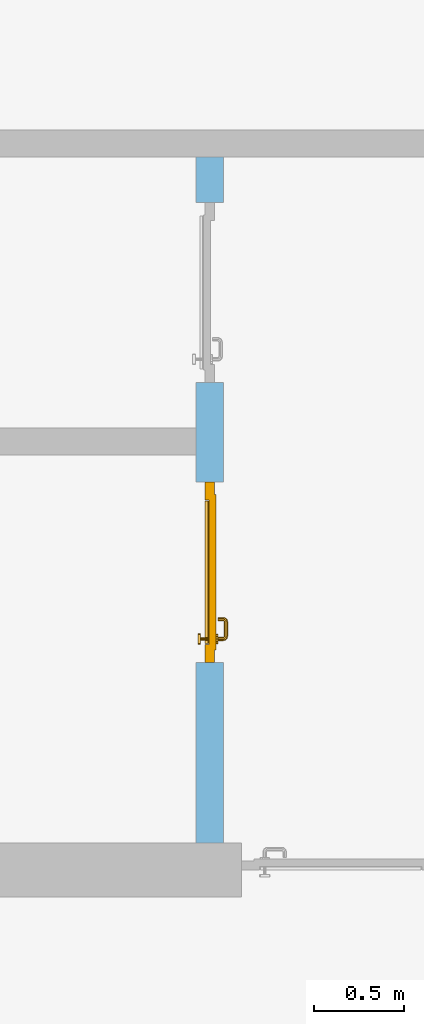
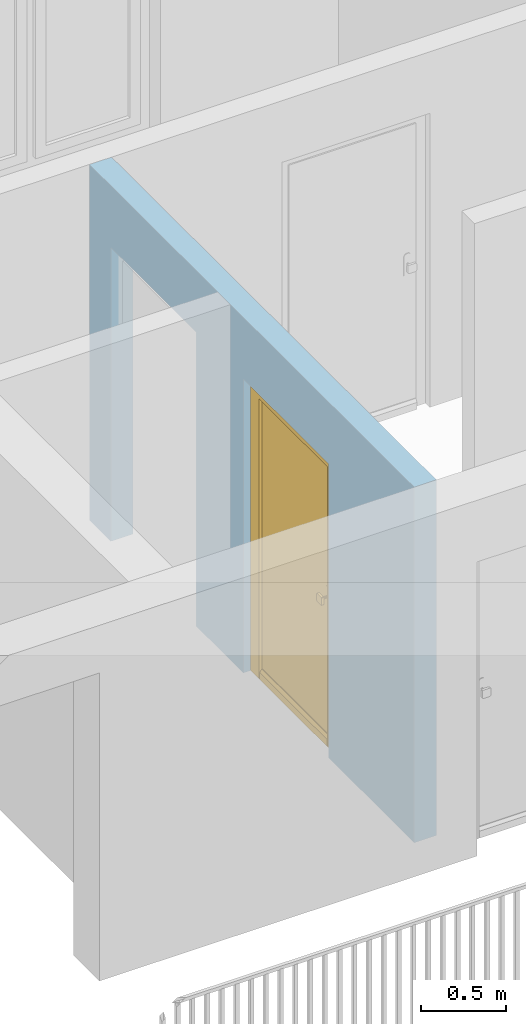
# One storey, part 19 of 54: 1 door, 2 openings, plus 1 element that does not belong to this part.
"""IFC4 building model written with IfcOpenShell, lengths in metres."""

from ifc_helpers import new_model, entity, si_unit, converted_unit, derived_unit, direction, frame, origin_with_axes, place, context, subcontext, project, spatial, polygons, source, transform, mapped, material, type_object, element, fill, save


model = new_model("IFC4")

# Units and contexts
model_context = context("Model", 3, precision=1e-05, world=origin_with_axes(), true_north=direction((0.0, 1.0)))
body_context = subcontext(model_context, "Body", "Model", "MODEL_VIEW")
ifc_project = project(units=[si_unit("LENGTHUNIT", "METRE"), si_unit("AREAUNIT", "SQUARE_METRE"), si_unit("VOLUMEUNIT", "CUBIC_METRE"), converted_unit("PLANEANGLEUNIT", "DEGREE", entity("IfcPlaneAngleMeasure", 0.0174532925199), si_unit("PLANEANGLEUNIT", "RADIAN"), dimensions=[0, 0, 0, 0, 0, 0, 0]), converted_unit("TIMEUNIT", "Year", entity("IfcTimeMeasure", 31556926.0), si_unit("TIMEUNIT", "SECOND"), dimensions=[0, 0, 1, 0, 0, 0, 0]), si_unit("MASSUNIT", "GRAM", prefix="KILO"), si_unit("THERMODYNAMICTEMPERATUREUNIT", "DEGREE_CELSIUS"), si_unit("LUMINOUSINTENSITYUNIT", "LUMEN"), si_unit("ENERGYUNIT", "JOULE", prefix="MEGA"), derived_unit("THERMALCONDUCTANCEUNIT", [(si_unit("POWERUNIT", "WATT"), 1), (si_unit("LENGTHUNIT", "METRE"), -1), (si_unit("THERMODYNAMICTEMPERATUREUNIT", "KELVIN"), -1)]), derived_unit("SPECIFICHEATCAPACITYUNIT", [(si_unit("ENERGYUNIT", "JOULE"), 1), (si_unit("MASSUNIT", "GRAM", prefix="KILO"), -1), (si_unit("THERMODYNAMICTEMPERATUREUNIT", "KELVIN"), -1)]), derived_unit("MASSDENSITYUNIT", [(si_unit("MASSUNIT", "GRAM", prefix="KILO"), 1), (si_unit("VOLUMEUNIT", "CUBIC_METRE"), -1)])], contexts=[model_context])

# Site, building, storey
site_placement = place(None, origin_with_axes())
site = spatial("IfcSite", under=ifc_project, at=site_placement, CompositionType="ELEMENT")
building_placement = place(site_placement, origin_with_axes())
building = spatial("IfcBuilding", under=site, at=building_placement, CompositionType="ELEMENT")
storey_placement = place(building_placement, frame((0.0, 0.0, 9.18), z_axis=(0.0, 0.0, 1.0), x_axis=(1.0, 0.0, 0.0)))
storey = spatial("IfcBuildingStorey", under=building, at=storey_placement, Name="3. Geschoss", CompositionType="ELEMENT", Elevation=9.18)

# Wall, openings, door
ifc_material = material()
wall_type = type_object("IfcWallType", Name="150", PredefinedType="NOTDEFINED")
wall_placement = place(storey_placement, frame((1.3378006196, 1.37118776896, 0.0), z_axis=(0.0, 0.0, 1.0), x_axis=(0.0, 1.0, 0.0)))
wall = element("IfcWall", 1, at=wall_placement, inside=storey, type_object=wall_type, material=ifc_material, Name="Wand-002", PredefinedType="NOTDEFINED", context=body_context, shape_type="Tessellation", body=[
    polygons([(1.3, 0.0, 0.0), (1.3, 0.0, 2.1), (2.3, 0.0, 2.1), (2.3, 0.0, 0.0), (2.85, 0.0, 0.0), (2.85, 0.0, 2.1), (3.85, 0.0, 2.1), (3.85, 0.0, 0.0), (4.1, 0.0, 0.0), (4.1, 0.0, 2.54), (0.3, 0.0, 2.54), (0.3, 0.0, 0.0), (1.3, 0.1, 0.0), (1.3, 0.15, 0.0), (1.3, 0.15, 2.1), (2.3, 0.15, 2.1), (2.3, 0.1, 0.0), (2.3, 0.15, 0.0), (2.85, 0.15, 0.0), (2.85, 0.15, 2.1), (3.85, 0.15, 2.1), (3.85, 0.15, 0.0), (4.1, 0.15, 0.0), (4.1, 0.15, 2.54), (0.3, 0.15, 2.54), (0.3, 0.15, 0.0)], [[[1, 2, 3, 4, 5, 6, 7, 8, 9, 10, 11, 12]], [[2, 1, 13, 14, 15]], [[3, 2, 15, 16]], [[17, 4, 3, 16, 18]], [[4, 17, 18, 19, 5]], [[19, 20, 6, 5]], [[20, 21, 7, 6]], [[21, 22, 8, 7]], [[23, 9, 8, 22]], [[23, 24, 10, 9]], [[25, 11, 10, 24]], [[12, 11, 25, 26]], [[13, 1, 12, 26, 14]], [[19, 18, 16, 15, 14, 26, 25, 24, 23, 22, 21, 20]]], closed=True),
])
opening_1_placement = place(wall_placement, frame((3.35, 0.0, 0.0), z_axis=(0.0, 0.0, 1.0), x_axis=(1.0, 0.0, 0.0)))
element("IfcOpeningElement", 2, at=opening_1_placement, cuts=wall, context=body_context, identifier="Reference", shape_type="Tessellation", body=[
    polygons([(-0.5, 0.1, 0.0), (-0.5, 0.1, 2.1), (-0.5, 0.151, 2.1), (-0.5, 0.151, 0.0), (-0.5, -0.001, 0.0), (-0.5, -0.001, 2.1), (0.5, 0.1, 2.1), (0.5, 0.151, 2.1), (0.5, -0.001, 2.1), (0.5, 0.151, 0.0), (0.5, 0.1, 0.0), (0.5, -0.001, 0.0)], [[[1, 2, 3, 4]], [[2, 1, 5, 6]], [[7, 8, 3, 2, 6, 9]], [[8, 10, 4, 3]], [[1, 4, 10, 11, 12, 5]], [[6, 5, 12, 9]], [[7, 11, 10, 8]], [[11, 7, 9, 12]]], closed=True),
])
opening_2_placement = place(wall_placement, frame((1.8, 0.0, 0.0), z_axis=(0.0, 0.0, 1.0), x_axis=(1.0, 0.0, 0.0)))
opening_2 = element("IfcOpeningElement", 3, at=opening_2_placement, cuts=wall, context=body_context, identifier="Reference", shape_type="Tessellation", body=[
    polygons([(-0.5, 0.1, 0.0), (-0.5, 0.1, 2.1), (-0.5, 0.151, 2.1), (-0.5, 0.151, 0.0), (-0.5, -0.001, 0.0), (-0.5, -0.001, 2.1), (0.5, 0.1, 2.1), (0.5, 0.151, 2.1), (0.5, -0.001, 2.1), (0.5, 0.151, 0.0), (0.5, 0.1, 0.0), (0.5, -0.001, 0.0)], [[[1, 2, 3, 4]], [[2, 1, 5, 6]], [[7, 8, 3, 2, 6, 9]], [[8, 10, 4, 3]], [[1, 4, 10, 11, 12, 5]], [[6, 5, 12, 9]], [[7, 11, 10, 8]], [[11, 7, 9, 12]]], closed=True),
])
door_type = type_object("IfcDoorType", Name="Eingang 01 1-Fl 26", OperationType="SINGLE_SWING_LEFT", PredefinedType="DOOR")
shared_shape = source(origin_with_axes(), body_context, "Body", "Tessellation", [
    polygons([(-0.5, -0.05, 0.0), (-0.5, -0.05, 2.1), (-0.5, -0.03, 2.1), (-0.5, -0.03, 0.0), (-0.4, -0.05, 0.0), (-0.4, -0.05, 2.0), (-0.1301, -0.05, 2.0), (-0.0001, -0.05, 2.0), (0.4, -0.05, 2.0), (0.4, -0.05, 0.0), (0.5, -0.05, 0.0), (0.5, -0.05, 2.1), (0.5, -0.03, 2.1), (0.5, -0.03, 0.0), (0.4, -0.03, 0.0), (0.4, -0.03, 2.0), (-0.0001, -0.03, 2.0), (-0.1301, -0.03, 2.0), (-0.4, -0.03, 2.0), (-0.4, -0.03, 0.0)], [[[1, 2, 3, 4]], [[1, 5, 6, 7, 8, 9, 10, 11, 12, 2]], [[2, 12, 13, 3]], [[4, 3, 13, 14, 15, 16, 17, 18, 19, 20]], [[5, 1, 4, 20]], [[6, 5, 20, 19]], [[7, 6, 19, 18]], [[8, 7, 18, 17]], [[9, 8, 17, 16]], [[10, 9, 16, 15]], [[11, 10, 15, 14]], [[12, 11, 14, 13]]], closed=True),
    polygons([(-0.5, -0.03, 0.0), (-0.5, -0.03, 2.1), (-0.5, 0.0, 2.1), (-0.5, 0.0, 0.0), (-0.43, -0.03, 0.0), (-0.43, -0.03, 2.03), (-0.1001, -0.03, 2.03), (-0.0301, -0.03, 2.03), (0.43, -0.03, 2.03), (0.43, -0.03, 0.0), (0.5, -0.03, 0.0), (0.5, -0.03, 2.1), (0.5, 0.0, 2.1), (0.5, 0.0, 0.0), (0.43, 0.0, 0.0), (0.43, 0.0, 2.03), (-0.0301, 0.0, 2.03), (-0.1001, 0.0, 2.03), (-0.43, 0.0, 2.03), (-0.43, 0.0, 0.0)], [[[1, 2, 3, 4]], [[1, 5, 6, 7, 8, 9, 10, 11, 12, 2]], [[2, 12, 13, 3]], [[4, 3, 13, 14, 15, 16, 17, 18, 19, 20]], [[5, 1, 4, 20]], [[6, 5, 20, 19]], [[7, 6, 19, 18]], [[8, 7, 18, 17]], [[9, 8, 17, 16]], [[10, 9, 16, 15]], [[11, 10, 15, 14]], [[12, 11, 14, 13]]], closed=True),
    polygons([(-0.43, 0.01, 0.0), (-0.43, 0.01, 2.03), (0.43, 0.01, 2.03), (0.43, 0.01, 0.0), (-0.43, -0.03, 0.0), (-0.43, -0.03, 2.03), (0.43, -0.03, 2.03), (0.43, -0.03, 0.0)], [[[1, 2, 3, 4]], [[1, 5, 6, 2]], [[2, 6, 7, 3]], [[3, 7, 8, 4]], [[4, 8, 5, 1]], [[8, 7, 6, 5]]], closed=True),
    polygons([(-0.395, -0.05, 0.0), (0.395, -0.05, 0.0), (0.395, -0.05, 0.05), (-0.395, -0.05, 0.05), (-0.395, -0.03, 0.0), (0.395, -0.03, 0.0), (0.395, -0.03, 0.07), (0.395, -0.035, 0.07), (-0.395, -0.035, 0.07), (-0.395, -0.03, 0.07)], [[[1, 2, 3, 4]], [[5, 6, 2, 1]], [[2, 6, 7, 8, 3]], [[4, 3, 8, 9]], [[1, 4, 9, 10, 5]], [[10, 7, 6, 5]], [[9, 8, 7, 10]]], closed=True),
    polygons([(0.3835, 0.02, 1.0733826859), (0.37, 0.02, 1.077), (0.37, 0.0199, 1.077), (0.3835, 0.0199, 1.0733826859), (0.393382685902, 0.02, 1.0635), (0.397, 0.02, 1.05), (0.393382685902, 0.02, 1.0365), (0.3835, 0.02, 1.0266173141), (0.37, 0.02, 1.023), (0.3565, 0.02, 1.0266173141), (0.346617314098, 0.02, 1.0365), (0.343, 0.02, 1.05), (0.346617314098, 0.02, 1.0635), (0.3565, 0.02, 1.0733826859), (0.3565, 0.0199, 1.0733826859), (0.37, 0.0101, 1.077), (0.3835, 0.0101, 1.0733826859), (0.393382685902, 0.0199, 1.0635), (0.397, 0.0199, 1.05), (0.393382685902, 0.0199, 1.0365), (0.3835, 0.0199, 1.0266173141), (0.37, 0.0199, 1.023), (0.3565, 0.0199, 1.0266173141), (0.346617314098, 0.0199, 1.0365), (0.343, 0.0199, 1.05), (0.346617314098, 0.0199, 1.0635), (0.3565, 0.0101, 1.0733826859), (0.37, 0.01, 1.077), (0.3835, 0.01, 1.0733826859), (0.393382685902, 0.0101, 1.0635), (0.397, 0.0101, 1.05), (0.393382685902, 0.0101, 1.0365), (0.3835, 0.0101, 1.0266173141), (0.37, 0.0101, 1.023), (0.3565, 0.0101, 1.0266173141), (0.346617314098, 0.0101, 1.0365), (0.343, 0.0101, 1.05), (0.346617314098, 0.0101, 1.0635), (0.3565, 0.01, 1.0733826859), (0.346617314098, 0.01, 1.0635), (0.343, 0.01, 1.05), (0.346617314098, 0.01, 1.0365), (0.3565, 0.01, 1.0266173141), (0.37, 0.01, 1.023), (0.3835, 0.01, 1.0266173141), (0.393382685902, 0.01, 1.0365), (0.397, 0.01, 1.05), (0.393382685902, 0.01, 1.0635)], [[[1, 2, 3, 4]], [[2, 1, 5, 6, 7, 8, 9, 10, 11, 12, 13, 14]], [[2, 14, 15, 3]], [[4, 3, 16, 17]], [[5, 1, 4, 18]], [[6, 5, 18, 19]], [[7, 6, 19, 20]], [[8, 7, 20, 21]], [[9, 8, 21, 22]], [[10, 9, 22, 23]], [[11, 10, 23, 24]], [[12, 11, 24, 25]], [[13, 12, 25, 26]], [[14, 13, 26, 15]], [[3, 15, 27, 16]], [[17, 16, 28, 29]], [[18, 4, 17, 30]], [[19, 18, 30, 31]], [[20, 19, 31, 32]], [[21, 20, 32, 33]], [[22, 21, 33, 34]], [[23, 22, 34, 35]], [[24, 23, 35, 36]], [[25, 24, 36, 37]], [[26, 25, 37, 38]], [[15, 26, 38, 27]], [[16, 27, 39, 28]], [[28, 39, 40, 41, 42, 43, 44, 45, 46, 47, 48, 29]], [[30, 17, 29, 48]], [[31, 30, 48, 47]], [[32, 31, 47, 46]], [[33, 32, 46, 45]], [[34, 33, 45, 44]], [[35, 34, 44, 43]], [[36, 35, 43, 42]], [[37, 36, 42, 41]], [[38, 37, 41, 40]], [[27, 38, 40, 39]]], closed=True),
    polygons([(0.362532169224, 0.019, 0.959692280177), (0.363279754556, 0.019, 0.961639806549), (0.35705, 0.019, 0.972430057958), (0.347569942042, 0.019, 0.96295), (0.365, 0.019, 0.952886751346), (0.365, 0.019, 0.9544), (0.362532169224, 0.02, 0.959692280177), (0.363279754556, 0.02, 0.961639806549), (0.364624817685, 0.02, 0.965143815798), (0.364624817685, 0.019, 0.965143815798), (0.37, 0.019, 0.967425445323), (0.37, 0.019, 0.9759), (0.357, 0.019, 0.972516660498), (0.347483339502, 0.019, 0.963), (0.365, 0.019, 0.95), (0.3441, 0.019, 0.95), (0.365, 0.019, 0.947113248654), (0.365, 0.019, 0.941339745962), (0.365, 0.019, 0.9375), (0.365, 0.02, 0.9375), (0.365, 0.02, 0.941339745962), (0.365, 0.02, 0.947113248654), (0.365, 0.02, 0.95), (0.365, 0.02, 0.952886751346), (0.365, 0.02, 0.9544), (0.346703916638, 0.02, 0.96345), (0.35655, 0.02, 0.973296083362), (0.37, 0.02, 0.9769), (0.37, 0.02, 0.967425445323), (0.375375182315, 0.019, 0.965143815798), (0.376720245444, 0.019, 0.961639806549), (0.38295, 0.019, 0.972430057958), (0.37, 0.019, 0.976), (0.357, 0.0189, 0.972516660498), (0.347483339502, 0.0189, 0.963), (0.344, 0.019, 0.95), (0.347569942042, 0.019, 0.93705), (0.35705, 0.019, 0.927569942042), (0.37, 0.019, 0.9241), (0.37, 0.019, 0.9325), (0.366464466094, 0.019, 0.933964466094), (0.366464466094, 0.02, 0.933964466094), (0.37, 0.02, 0.9231), (0.35655, 0.02, 0.926703916638), (0.37, 0.02, 0.9325), (0.346703916638, 0.02, 0.93655), (0.3431, 0.02, 0.95), (0.346617314098, 0.02, 0.9635), (0.3565, 0.02, 0.973382685902), (0.37, 0.02, 0.977), (0.375375182315, 0.02, 0.965143815798), (0.38345, 0.02, 0.973296083362), (0.376720245444, 0.02, 0.961639806549), (0.377467830776, 0.02, 0.959692280177), (0.377467830776, 0.019, 0.959692280177), (0.375, 0.019, 0.9544), (0.375, 0.019, 0.952886751346), (0.392430057958, 0.019, 0.96295), (0.383, 0.019, 0.972516660498), (0.37, 0.0189, 0.976), (0.357, 0.0101, 0.972516660498), (0.347483339502, 0.0101, 0.963), (0.344, 0.0189, 0.95), (0.347483339502, 0.019, 0.937), (0.357, 0.019, 0.927483339502), (0.37, 0.019, 0.924), (0.38295, 0.019, 0.927569942042), (0.375, 0.019, 0.941339745962), (0.375, 0.019, 0.9375), (0.373535533906, 0.019, 0.933964466094), (0.37, 0.02, 0.923), (0.3565, 0.02, 0.926617314098), (0.38345, 0.02, 0.926703916638), (0.373535533906, 0.02, 0.933964466094), (0.375, 0.02, 0.9375), (0.375, 0.02, 0.941339745962), (0.346617314098, 0.02, 0.9365), (0.343, 0.02, 0.95), (0.346617314098, 0.0199, 0.9635), (0.3565, 0.0199, 0.973382685902), (0.37, 0.0199, 0.977), (0.3835, 0.02, 0.973382685902), (0.393296083362, 0.02, 0.96345), (0.375, 0.02, 0.952886751346), (0.375, 0.02, 0.9544), (0.375, 0.02, 0.95), (0.375, 0.02, 0.947113248654), (0.375, 0.019, 0.947113248654), (0.375, 0.019, 0.95), (0.3959, 0.019, 0.95), (0.392516660498, 0.019, 0.963), (0.383, 0.0189, 0.972516660498), (0.37, 0.0101, 0.976), (0.357, 0.01, 0.972516660498), (0.347483339502, 0.01, 0.963), (0.344, 0.0101, 0.95), (0.347483339502, 0.0189, 0.937), (0.357, 0.0189, 0.927483339502), (0.37, 0.0189, 0.924), (0.383, 0.019, 0.927483339502), (0.392430057958, 0.019, 0.93705), (0.37, 0.0199, 0.923), (0.3565, 0.0199, 0.926617314098), (0.3835, 0.02, 0.926617314098), (0.393296083362, 0.02, 0.93655), (0.346617314098, 0.0199, 0.9365), (0.343, 0.0199, 0.95), (0.346617314098, 0.0101, 0.9635), (0.3565, 0.0101, 0.973382685902), (0.37, 0.0101, 0.977), (0.3835, 0.0199, 0.973382685902), (0.393382685902, 0.02, 0.9635), (0.3969, 0.02, 0.95), (0.396, 0.019, 0.95), (0.392516660498, 0.0189, 0.963), (0.383, 0.0101, 0.972516660498), (0.37, 0.01, 0.976), (0.35695, 0.01, 0.972603263039), (0.347396736961, 0.01, 0.96305), (0.344, 0.01, 0.95), (0.347483339502, 0.0101, 0.937), (0.357, 0.0101, 0.927483339502), (0.37, 0.0101, 0.924), (0.383, 0.0189, 0.927483339502), (0.392516660498, 0.019, 0.937), (0.37, 0.0101, 0.923), (0.3565, 0.0101, 0.926617314098), (0.3835, 0.0199, 0.926617314098), (0.393382685902, 0.02, 0.9365), (0.346617314098, 0.0101, 0.9365), (0.343, 0.0101, 0.95), (0.346617314098, 0.01, 0.9635), (0.3565, 0.01, 0.973382685902), (0.37, 0.01, 0.977), (0.3835, 0.0101, 0.973382685902), (0.393382685902, 0.0199, 0.9635), (0.397, 0.02, 0.95), (0.396, 0.0189, 0.95), (0.392516660498, 0.0101, 0.963), (0.383, 0.01, 0.972516660498), (0.37, 0.01, 0.9761), (0.35655, 0.01, 0.973296083362), (0.346703916638, 0.01, 0.96345), (0.3439, 0.01, 0.95), (0.347483339502, 0.01, 0.937), (0.357, 0.01, 0.927483339502), (0.37, 0.01, 0.924), (0.383, 0.0101, 0.927483339502), (0.392516660498, 0.0189, 0.937), (0.37, 0.01, 0.923), (0.3565, 0.01, 0.926617314098), (0.3835, 0.0101, 0.926617314098), (0.393382685902, 0.0199, 0.9365), (0.346617314098, 0.01, 0.9365), (0.343, 0.01, 0.95), (0.37, 0.01, 0.9769), (0.3835, 0.01, 0.973382685902), (0.393382685902, 0.0101, 0.9635), (0.397, 0.0199, 0.95), (0.396, 0.0101, 0.95), (0.392516660498, 0.01, 0.963), (0.38305, 0.01, 0.972603263039), (0.3431, 0.01, 0.95), (0.347396736961, 0.01, 0.93695), (0.35695, 0.01, 0.927396736961), (0.37, 0.01, 0.9239), (0.383, 0.01, 0.927483339502), (0.392516660498, 0.0101, 0.937), (0.37, 0.01, 0.9231), (0.35655, 0.01, 0.926703916638), (0.3835, 0.01, 0.926617314098), (0.393382685902, 0.0101, 0.9365), (0.346703916638, 0.01, 0.93655), (0.38345, 0.01, 0.973296083362), (0.393382685902, 0.01, 0.9635), (0.397, 0.0101, 0.95), (0.396, 0.01, 0.95), (0.392603263039, 0.01, 0.96305), (0.38305, 0.01, 0.927396736961), (0.392516660498, 0.01, 0.937), (0.38345, 0.01, 0.926703916638), (0.393382685902, 0.01, 0.9365), (0.393296083362, 0.01, 0.96345), (0.397, 0.01, 0.95), (0.3961, 0.01, 0.95), (0.392603263039, 0.01, 0.93695), (0.393296083362, 0.01, 0.93655), (0.3969, 0.01, 0.95)], [[[1, 2, 3, 4, 5, 6]], [[1, 7, 8, 9, 10, 2]], [[10, 11, 12, 3, 2]], [[4, 3, 13, 14]], [[15, 5, 4, 16]], [[6, 5, 15, 17, 18, 19, 20, 21, 22, 23, 24, 25]], [[6, 25, 7, 1]], [[7, 25, 24, 26, 27, 8]], [[9, 8, 27, 28, 29]], [[10, 9, 29, 11]], [[30, 31, 32, 12, 11]], [[3, 12, 33, 13]], [[14, 13, 34, 35]], [[16, 4, 14, 36]], [[17, 15, 16, 37]], [[18, 17, 37, 38]], [[38, 39, 40, 41, 19, 18]], [[19, 41, 42, 20]], [[43, 44, 21, 20, 42, 45]], [[22, 21, 44, 46]], [[23, 22, 46, 47]], [[24, 23, 47, 26]], [[48, 49, 27, 26]], [[49, 50, 28, 27]], [[51, 29, 28, 52, 53]], [[11, 29, 51, 30]], [[30, 51, 53, 54, 55, 31]], [[55, 56, 57, 58, 32, 31]], [[12, 32, 59, 33]], [[13, 33, 60, 34]], [[35, 34, 61, 62]], [[36, 14, 35, 63]], [[37, 16, 36, 64]], [[38, 37, 64, 65]], [[39, 38, 65, 66]], [[39, 67, 68, 69, 70, 40]], [[41, 40, 45, 42]], [[71, 72, 44, 43]], [[73, 43, 45, 74, 75, 76]], [[72, 77, 46, 44]], [[77, 78, 47, 46]], [[78, 48, 26, 47]], [[79, 80, 49, 48]], [[80, 81, 50, 49]], [[50, 82, 52, 28]], [[54, 53, 52, 83, 84, 85]], [[55, 54, 85, 56]], [[85, 84, 86, 87, 76, 75, 69, 68, 88, 89, 57, 56]], [[57, 89, 90, 58]], [[32, 58, 91, 59]], [[33, 59, 92, 60]], [[34, 60, 93, 61]], [[62, 61, 94, 95]], [[63, 35, 62, 96]], [[64, 36, 63, 97]], [[65, 64, 97, 98]], [[66, 65, 98, 99]], [[67, 39, 66, 100]], [[88, 68, 67, 101]], [[70, 69, 75, 74]], [[40, 70, 74, 45]], [[102, 103, 72, 71]], [[104, 71, 43, 73]], [[76, 87, 105, 73]], [[103, 106, 77, 72]], [[106, 107, 78, 77]], [[107, 79, 48, 78]], [[108, 109, 80, 79]], [[109, 110, 81, 80]], [[81, 111, 82, 50]], [[82, 112, 83, 52]], [[86, 84, 83, 113]], [[87, 86, 113, 105]], [[89, 88, 101, 90]], [[58, 90, 114, 91]], [[59, 91, 115, 92]], [[60, 92, 116, 93]], [[61, 93, 117, 94]], [[95, 94, 118, 119]], [[96, 62, 95, 120]], [[97, 63, 96, 121]], [[98, 97, 121, 122]], [[99, 98, 122, 123]], [[100, 66, 99, 124]], [[101, 67, 100, 125]], [[126, 127, 103, 102]], [[128, 102, 71, 104]], [[129, 104, 73, 105]], [[127, 130, 106, 103]], [[130, 131, 107, 106]], [[131, 108, 79, 107]], [[132, 133, 109, 108]], [[133, 134, 110, 109]], [[110, 135, 111, 81]], [[111, 136, 112, 82]], [[112, 137, 113, 83]], [[137, 129, 105, 113]], [[90, 101, 125, 114]], [[91, 114, 138, 115]], [[92, 115, 139, 116]], [[93, 116, 140, 117]], [[94, 117, 141, 118]], [[119, 118, 142, 143]], [[120, 95, 119, 144]], [[121, 96, 120, 145]], [[122, 121, 145, 146]], [[123, 122, 146, 147]], [[124, 99, 123, 148]], [[125, 100, 124, 149]], [[150, 151, 127, 126]], [[152, 126, 102, 128]], [[153, 128, 104, 129]], [[151, 154, 130, 127]], [[154, 155, 131, 130]], [[155, 132, 108, 131]], [[143, 142, 133, 132]], [[142, 156, 134, 133]], [[134, 157, 135, 110]], [[135, 158, 136, 111]], [[136, 159, 137, 112]], [[159, 153, 129, 137]], [[114, 125, 149, 138]], [[115, 138, 160, 139]], [[116, 139, 161, 140]], [[117, 140, 162, 141]], [[118, 141, 156, 142]], [[144, 119, 143, 163]], [[145, 120, 144, 164]], [[146, 145, 164, 165]], [[147, 146, 165, 166]], [[148, 123, 147, 167]], [[149, 124, 148, 168]], [[169, 170, 151, 150]], [[171, 150, 126, 152]], [[172, 152, 128, 153]], [[170, 173, 154, 151]], [[173, 163, 155, 154]], [[163, 143, 132, 155]], [[156, 174, 157, 134]], [[157, 175, 158, 135]], [[158, 176, 159, 136]], [[176, 172, 153, 159]], [[138, 149, 168, 160]], [[139, 160, 177, 161]], [[140, 161, 178, 162]], [[141, 162, 174, 156]], [[164, 144, 163, 173]], [[165, 164, 173, 170]], [[166, 165, 170, 169]], [[167, 147, 166, 179]], [[168, 148, 167, 180]], [[181, 169, 150, 171]], [[182, 171, 152, 172]], [[174, 183, 175, 157]], [[175, 184, 176, 158]], [[184, 182, 172, 176]], [[160, 168, 180, 177]], [[161, 177, 185, 178]], [[162, 178, 183, 174]], [[179, 166, 169, 181]], [[180, 167, 179, 186]], [[187, 181, 171, 182]], [[183, 188, 184, 175]], [[188, 187, 182, 184]], [[177, 180, 186, 185]], [[178, 185, 188, 183]], [[186, 179, 181, 187]], [[185, 186, 187, 188]]], closed=True),
    polygons([(0.38, 0.02, 1.05), (0.377071067812, 0.02, 1.04292893219), (0.377071067812, 0.050696439392, 1.04292893219), (0.38, 0.0509849140336, 1.05), (0.37, 0.02, 1.04), (0.37, 0.05, 1.04), (0.375518993221, 0.0584992452783, 1.04292893219), (0.378277987014, 0.0596420579258, 1.05), (0.377071067812, 0.02, 1.05707106781), (0.377071067812, 0.050696439392, 1.05707106781), (0.362928932188, 0.02, 1.04292893219), (0.362928932188, 0.049303560608, 1.04292893219), (0.368858192988, 0.0557402514855, 1.04), (0.370704557509, 0.0657045575088, 1.04292893219), (0.372816199938, 0.0678161999379, 1.05), (0.375518993221, 0.0584992452783, 1.05707106781), (0.37, 0.02, 1.06), (0.37, 0.05, 1.06), (0.36, 0.02, 1.05), (0.36, 0.0490150859664, 1.05), (0.362197392755, 0.0529812576926, 1.04292893219), (0.365606601718, 0.0606066017178, 1.04), (0.363499245278, 0.0705189932208, 1.04292893219), (0.364642057926, 0.0732779870137, 1.05), (0.370704557509, 0.0657045575088, 1.05707106781), (0.368858192988, 0.0557402514855, 1.06), (0.362928932188, 0.02, 1.05707106781), (0.362928932188, 0.049303560608, 1.05707106781), (0.359438398962, 0.0518384450452, 1.05), (0.360508645927, 0.0555086459268, 1.04292893219), (0.360740251485, 0.0638581929877, 1.04), (0.355696439392, 0.0720710678119, 1.04292893219), (0.355984914034, 0.075, 1.05), (0.363499245278, 0.0705189932208, 1.05707106781), (0.365606601718, 0.0606066017178, 1.06), (0.362197392755, 0.0529812576926, 1.05707106781), (0.358397003498, 0.0533970034977, 1.05), (0.357981257693, 0.0571973927545, 1.04292893219), (0.355, 0.065, 1.04), (0.274303560608, 0.0720710678119, 1.04292893219), (0.274015085966, 0.075, 1.05), (0.355696439392, 0.0720710678119, 1.05707106781), (0.360740251485, 0.0638581929877, 1.06), (0.360508645927, 0.0555086459268, 1.05707106781), (0.356838445045, 0.0544383989617, 1.05), (0.354303560608, 0.0579289321881, 1.04292893219), (0.275, 0.065, 1.04), (0.266500754722, 0.0705189932208, 1.04292893219), (0.265357942074, 0.0732779870137, 1.05), (0.274303560608, 0.0720710678119, 1.05707106781), (0.355, 0.065, 1.06), (0.357981257693, 0.0571973927545, 1.05707106781), (0.354015085966, 0.055, 1.05), (0.275696439392, 0.0579289321881, 1.04292893219), (0.269259748515, 0.0638581929877, 1.04), (0.259295442491, 0.0657045575088, 1.04292893219), (0.257183800062, 0.0678161999379, 1.05), (0.266500754722, 0.0705189932208, 1.05707106781), (0.275, 0.065, 1.06), (0.354303560608, 0.0579289321881, 1.05707106781), (0.275984914034, 0.055, 1.05), (0.272018742307, 0.0571973927545, 1.04292893219), (0.264393398282, 0.0606066017178, 1.04), (0.254481006779, 0.0584992452783, 1.04292893219), (0.251722012986, 0.0596420579258, 1.05), (0.259295442491, 0.0657045575088, 1.05707106781), (0.269259748515, 0.0638581929877, 1.06), (0.275696439392, 0.0579289321881, 1.05707106781), (0.273161554955, 0.0544383989617, 1.05), (0.269491354073, 0.0555086459268, 1.04292893219), (0.261141807012, 0.0557402514855, 1.04), (0.252928932188, 0.050696439392, 1.04292893219), (0.25, 0.0509849140336, 1.05), (0.254481006779, 0.0584992452783, 1.05707106781), (0.264393398282, 0.0606066017178, 1.06), (0.272018742307, 0.0571973927545, 1.05707106781), (0.271602996502, 0.0533970034977, 1.05), (0.267802607245, 0.0529812576926, 1.04292893219), (0.26, 0.05, 1.04), (0.252928932188, 0.02, 1.04292893219), (0.25, 0.02, 1.05), (0.252928932188, 0.050696439392, 1.05707106781), (0.261141807012, 0.0557402514855, 1.06), (0.269491354073, 0.0555086459268, 1.05707106781), (0.270561601038, 0.0518384450452, 1.05), (0.267071067812, 0.049303560608, 1.04292893219), (0.26, 0.02, 1.04), (0.267071067812, 0.02, 1.04292893219), (0.27, 0.02, 1.05), (0.267071067812, 0.02, 1.05707106781), (0.26, 0.02, 1.06), (0.252928932188, 0.02, 1.05707106781), (0.26, 0.05, 1.06), (0.267802607245, 0.0529812576926, 1.05707106781), (0.27, 0.0490150859664, 1.05), (0.267071067812, 0.049303560608, 1.05707106781)], [[[1, 2, 3, 4]], [[2, 5, 6, 3]], [[4, 3, 7, 8]], [[9, 1, 4, 10]], [[5, 11, 12, 6]], [[3, 6, 13, 7]], [[8, 7, 14, 15]], [[10, 4, 8, 16]], [[17, 9, 10, 18]], [[11, 19, 20, 12]], [[6, 12, 21, 13]], [[7, 13, 22, 14]], [[15, 14, 23, 24]], [[16, 8, 15, 25]], [[18, 10, 16, 26]], [[27, 17, 18, 28]], [[19, 27, 28, 20]], [[12, 20, 29, 21]], [[13, 21, 30, 22]], [[14, 22, 31, 23]], [[24, 23, 32, 33]], [[25, 15, 24, 34]], [[26, 16, 25, 35]], [[28, 18, 26, 36]], [[20, 28, 36, 29]], [[21, 29, 37, 30]], [[22, 30, 38, 31]], [[23, 31, 39, 32]], [[33, 32, 40, 41]], [[34, 24, 33, 42]], [[35, 25, 34, 43]], [[36, 26, 35, 44]], [[29, 36, 44, 37]], [[30, 37, 45, 38]], [[31, 38, 46, 39]], [[32, 39, 47, 40]], [[41, 40, 48, 49]], [[42, 33, 41, 50]], [[43, 34, 42, 51]], [[44, 35, 43, 52]], [[37, 44, 52, 45]], [[38, 45, 53, 46]], [[39, 46, 54, 47]], [[40, 47, 55, 48]], [[49, 48, 56, 57]], [[50, 41, 49, 58]], [[51, 42, 50, 59]], [[52, 43, 51, 60]], [[45, 52, 60, 53]], [[46, 53, 61, 54]], [[47, 54, 62, 55]], [[48, 55, 63, 56]], [[57, 56, 64, 65]], [[58, 49, 57, 66]], [[59, 50, 58, 67]], [[60, 51, 59, 68]], [[53, 60, 68, 61]], [[54, 61, 69, 62]], [[55, 62, 70, 63]], [[56, 63, 71, 64]], [[65, 64, 72, 73]], [[66, 57, 65, 74]], [[67, 58, 66, 75]], [[68, 59, 67, 76]], [[61, 68, 76, 69]], [[62, 69, 77, 70]], [[63, 70, 78, 71]], [[64, 71, 79, 72]], [[73, 72, 80, 81]], [[74, 65, 73, 82]], [[75, 66, 74, 83]], [[76, 67, 75, 84]], [[69, 76, 84, 77]], [[70, 77, 85, 78]], [[71, 78, 86, 79]], [[72, 79, 87, 80]], [[81, 80, 87, 88, 89, 90, 91, 92]], [[82, 73, 81, 92]], [[83, 74, 82, 93]], [[84, 75, 83, 94]], [[77, 84, 94, 85]], [[78, 85, 95, 86]], [[79, 86, 88, 87]], [[86, 95, 89, 88]], [[95, 96, 90, 89]], [[96, 93, 91, 90]], [[93, 82, 92, 91]], [[94, 83, 93, 96]], [[85, 94, 96, 95]]], closed=False),
    polygons([(0.364696699141, -0.035, 1.04469669914), (0.3625, -0.035, 1.05), (0.364696699141, -0.035, 1.05530330086), (0.37, -0.035, 1.0575), (0.375303300859, -0.035, 1.05530330086), (0.3775, -0.035, 1.05), (0.375303300859, -0.035, 1.04469669914), (0.37, -0.035, 1.0425), (0.364696699141, -0.075, 1.04469669914), (0.3625, -0.075, 1.05), (0.364696699141, -0.075, 1.05530330086), (0.37, -0.075, 1.0575), (0.375303300859, -0.075, 1.05530330086), (0.3775, -0.075, 1.05), (0.375303300859, -0.075, 1.04469669914), (0.37, -0.075, 1.0425)], [[[1, 2, 3, 4, 5, 6, 7, 8]], [[1, 9, 10, 2]], [[2, 10, 11, 3]], [[3, 11, 12, 4]], [[4, 12, 13, 5]], [[5, 13, 14, 6]], [[6, 14, 15, 7]], [[7, 15, 16, 8]], [[8, 16, 9, 1]], [[9, 16, 15, 14, 13, 12, 11, 10]]], closed=True),
    polygons([(0.395, -0.03, 0.975), (0.395, -0.035, 0.975), (0.393096988313, -0.035, 0.965432914191), (0.393096988313, -0.03, 0.965432914191), (0.395, -0.03, 1.1), (0.395, -0.035, 1.1), (0.393096988313, -0.035, 1.10956708581), (0.38767766953, -0.035, 1.11767766953), (0.379567085809, -0.035, 1.12309698831), (0.37, -0.035, 1.125), (0.360432914191, -0.035, 1.12309698831), (0.35232233047, -0.035, 1.11767766953), (0.346903011687, -0.035, 1.10956708581), (0.345, -0.035, 1.1), (0.345, -0.035, 0.975), (0.346903011687, -0.035, 0.965432914191), (0.35232233047, -0.035, 0.95732233047), (0.360432914191, -0.035, 0.951903011687), (0.37, -0.035, 0.95), (0.379567085809, -0.035, 0.951903011687), (0.38767766953, -0.035, 0.95732233047), (0.38767766953, -0.03, 0.95732233047), (0.379567085809, -0.03, 0.951903011687), (0.37, -0.03, 0.95), (0.360432914191, -0.03, 0.951903011687), (0.35232233047, -0.03, 0.95732233047), (0.346903011687, -0.03, 0.965432914191), (0.345, -0.03, 0.975), (0.345, -0.03, 1.1), (0.346903011687, -0.03, 1.10956708581), (0.35232233047, -0.03, 1.11767766953), (0.360432914191, -0.03, 1.12309698831), (0.37, -0.03, 1.125), (0.379567085809, -0.03, 1.12309698831), (0.38767766953, -0.03, 1.11767766953), (0.393096988313, -0.03, 1.10956708581)], [[[1, 2, 3, 4]], [[5, 6, 2, 1]], [[2, 6, 7, 8, 9, 10, 11, 12, 13, 14, 15, 16, 17, 18, 19, 20, 21, 3]], [[4, 3, 21, 22]], [[1, 4, 22, 23, 24, 25, 26, 27, 28, 29, 30, 31, 32, 33, 34, 35, 36, 5]], [[36, 7, 6, 5]], [[35, 8, 7, 36]], [[34, 9, 8, 35]], [[33, 10, 9, 34]], [[32, 11, 10, 33]], [[31, 12, 11, 32]], [[30, 13, 12, 31]], [[29, 14, 13, 30]], [[28, 15, 14, 29]], [[27, 16, 15, 28]], [[26, 17, 16, 27]], [[25, 18, 17, 26]], [[24, 19, 18, 25]], [[23, 20, 19, 24]], [[22, 21, 20, 23]]], closed=True),
    polygons([(0.39, -0.075, 1.08), (0.39, -0.09, 1.08), (0.395, -0.09, 1.07866025404), (0.395, -0.075, 1.07866025404), (0.35, -0.075, 1.08), (0.35, -0.09, 1.08), (0.345, -0.09, 1.07866025404), (0.341339745962, -0.09, 1.075), (0.34, -0.09, 1.07), (0.34, -0.09, 1.03), (0.341339745962, -0.09, 1.025), (0.345, -0.09, 1.02133974596), (0.35, -0.09, 1.02), (0.39, -0.09, 1.02), (0.395, -0.09, 1.02133974596), (0.398660254038, -0.09, 1.025), (0.4, -0.09, 1.03), (0.4, -0.09, 1.07), (0.398660254038, -0.09, 1.075), (0.398660254038, -0.075, 1.075), (0.4, -0.075, 1.07), (0.4, -0.075, 1.03), (0.398660254038, -0.075, 1.025), (0.395, -0.075, 1.02133974596), (0.39, -0.075, 1.02), (0.35, -0.075, 1.02), (0.345, -0.075, 1.02133974596), (0.341339745962, -0.075, 1.025), (0.34, -0.075, 1.03), (0.34, -0.075, 1.07), (0.341339745962, -0.075, 1.075), (0.345, -0.075, 1.07866025404)], [[[1, 2, 3, 4]], [[5, 6, 2, 1]], [[2, 6, 7, 8, 9, 10, 11, 12, 13, 14, 15, 16, 17, 18, 19, 3]], [[4, 3, 19, 20]], [[1, 4, 20, 21, 22, 23, 24, 25, 26, 27, 28, 29, 30, 31, 32, 5]], [[32, 7, 6, 5]], [[31, 8, 7, 32]], [[30, 9, 8, 31]], [[29, 10, 9, 30]], [[28, 11, 10, 29]], [[27, 12, 11, 28]], [[26, 13, 12, 27]], [[25, 14, 13, 26]], [[24, 15, 14, 25]], [[23, 16, 15, 24]], [[22, 17, 16, 23]], [[21, 18, 17, 22]], [[20, 19, 18, 21]]], closed=True),
])
door_placement = place(opening_2_placement, frame((0.4, 0.0, 0.0), z_axis=(0.0, 0.0, 1.0), x_axis=(-1.0, 0.0, 0.0)))
door = element("IfcDoor", 4, at=door_placement, inside=storey, type_object=door_type, OverallHeight=2.1, OverallWidth=1.0, PredefinedType="DOOR", context=body_context, shape_type="MappedRepresentation", body=[
    mapped(shared_shape, transform((0.4, -0.05, 0.0))),
])
fill(opening_2, door)

save(model, "model.ifc")
